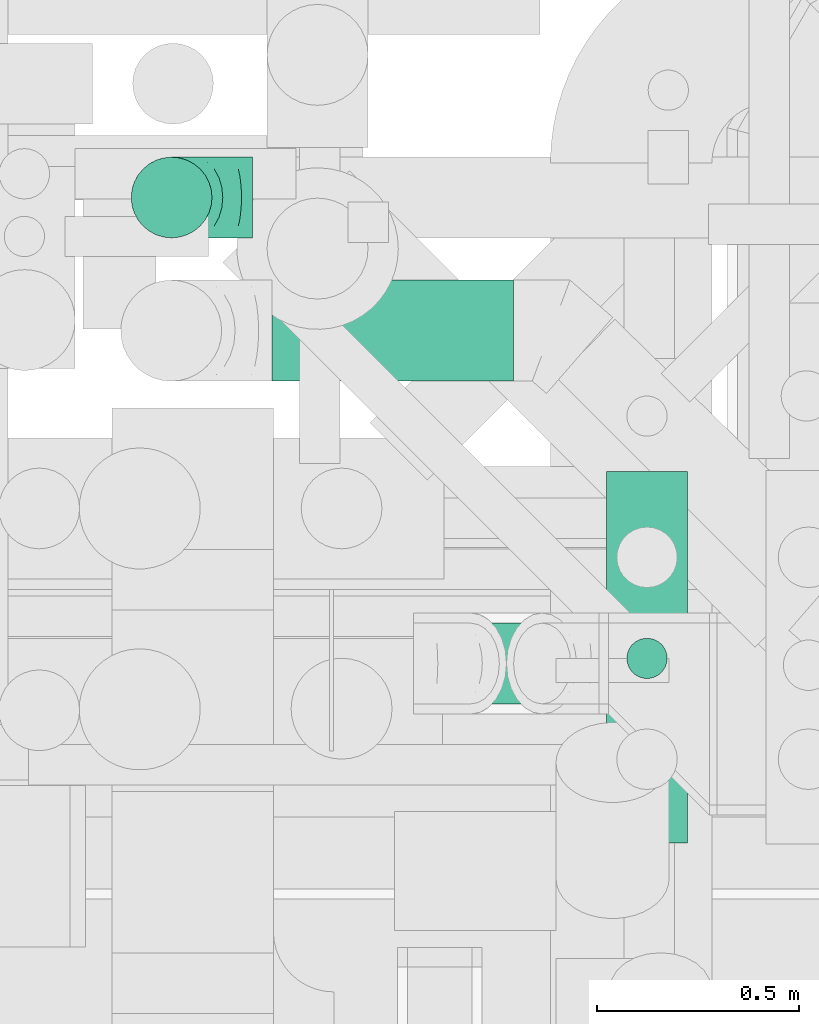
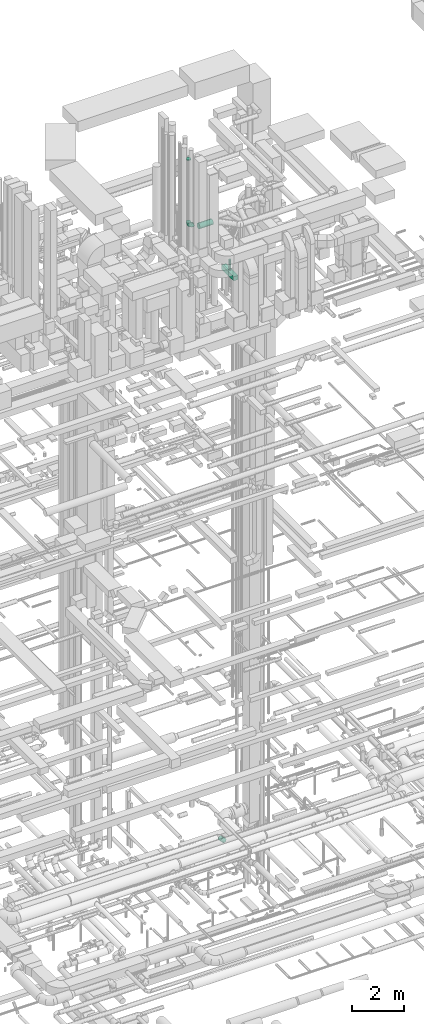
# One storey, part 227 of 337: 4 flow segments, 2 flow fittings.
"""IFC2X3 building model written with IfcOpenShell, lengths in millimetres."""

from ifc_helpers import new_model, entity, si_unit, converted_unit, derived_unit, direction, frame, origin, origin_2d_with_axis, place, context, subcontext, project, spatial, rectangle, circle, extrude, faceted_brep, source, transform, mapped, material, type_object, type_shapes, element, save


model = new_model("IFC2X3")

# Units and contexts
model_context = context("Model", 3, precision=0.01, world=origin(), true_north=direction((6.12303176911189e-17, 1.0)))
body_context = subcontext(model_context, "Body", "Model", "MODEL_VIEW")
ifc_project = project(units=[si_unit("LENGTHUNIT", "METRE", prefix="MILLI"), si_unit("AREAUNIT", "SQUARE_METRE"), si_unit("VOLUMEUNIT", "CUBIC_METRE"), converted_unit("PLANEANGLEUNIT", "DEGREE", entity("IfcRatioMeasure", 0.0174532925199433), si_unit("PLANEANGLEUNIT", "RADIAN"), dimensions=[0, 0, 0, 0, 0, 0, 0]), si_unit("MASSUNIT", "GRAM", prefix="KILO"), derived_unit("MASSDENSITYUNIT", [(si_unit("MASSUNIT", "GRAM", prefix="KILO"), 1), (si_unit("LENGTHUNIT", "METRE"), -3)]), derived_unit("MOMENTOFINERTIAUNIT", [(si_unit("LENGTHUNIT", "METRE"), 4)]), si_unit("TIMEUNIT", "SECOND"), si_unit("FREQUENCYUNIT", "HERTZ"), si_unit("THERMODYNAMICTEMPERATUREUNIT", "DEGREE_CELSIUS"), derived_unit("THERMALTRANSMITTANCEUNIT", [(si_unit("MASSUNIT", "GRAM", prefix="KILO"), 1), (si_unit("THERMODYNAMICTEMPERATUREUNIT", "KELVIN"), -1), (si_unit("TIMEUNIT", "SECOND"), -3)]), derived_unit("VOLUMETRICFLOWRATEUNIT", [(si_unit("LENGTHUNIT", "METRE"), 3), (si_unit("TIMEUNIT", "SECOND"), -1)]), derived_unit("MASSFLOWRATEUNIT", [(si_unit("MASSUNIT", "GRAM", prefix="KILO"), 1), (si_unit("TIMEUNIT", "SECOND"), -1)]), derived_unit("ROTATIONALFREQUENCYUNIT", [(si_unit("TIMEUNIT", "SECOND"), -1)]), si_unit("ELECTRICCURRENTUNIT", "AMPERE"), si_unit("ELECTRICVOLTAGEUNIT", "VOLT"), si_unit("POWERUNIT", "WATT"), si_unit("FORCEUNIT", "NEWTON", prefix="KILO"), si_unit("ILLUMINANCEUNIT", "LUX"), si_unit("LUMINOUSFLUXUNIT", "LUMEN"), si_unit("LUMINOUSINTENSITYUNIT", "CANDELA"), derived_unit("USERDEFINED", [(si_unit("MASSUNIT", "GRAM", prefix="KILO"), -1), (si_unit("LENGTHUNIT", "METRE"), -2), (si_unit("TIMEUNIT", "SECOND"), 3), (si_unit("LUMINOUSFLUXUNIT", "LUMEN"), 1)]), derived_unit("LINEARVELOCITYUNIT", [(si_unit("LENGTHUNIT", "METRE"), 1), (si_unit("TIMEUNIT", "SECOND"), -1)]), si_unit("PRESSUREUNIT", "PASCAL"), derived_unit("USERDEFINED", [(si_unit("LENGTHUNIT", "METRE"), -2), (si_unit("MASSUNIT", "GRAM", prefix="KILO"), 1), (si_unit("TIMEUNIT", "SECOND"), -2)]), derived_unit("LINEARFORCEUNIT", [(si_unit("MASSUNIT", "GRAM", prefix="KILO"), 1), (si_unit("LENGTHUNIT", "METRE"), 1), (si_unit("TIMEUNIT", "SECOND"), -2), (si_unit("LENGTHUNIT", "METRE"), -1)]), derived_unit("PLANARFORCEUNIT", [(si_unit("MASSUNIT", "GRAM", prefix="KILO"), 1), (si_unit("LENGTHUNIT", "METRE"), 1), (si_unit("TIMEUNIT", "SECOND"), -2), (si_unit("LENGTHUNIT", "METRE"), -2)])], contexts=[model_context])

# Site, building, storey
site_placement = place(None, origin())
site = spatial("IfcSite", under=ifc_project, at=site_placement, CompositionType="ELEMENT")
building_placement = place(site_placement, origin())
building = spatial("IfcBuilding", under=site, at=building_placement, CompositionType="ELEMENT")
storey_placement = place(building_placement, origin())
storey = spatial("IfcBuildingStorey", under=building, at=storey_placement, CompositionType="ELEMENT", Elevation=0.0)

# Flow segments
duct_segment_type_1 = type_object("IfcDuctSegmentType", PredefinedType="NOTDEFINED")
flow_segment_1_placement = place(storey_placement, frame((57036.5, 9405.81, 29700.0)))
element("IfcFlowSegment", 1, at=flow_segment_1_placement, inside=storey, type_object=duct_segment_type_1, context=body_context, shape_type="SweptSolid", body=[
    extrude(rectangle(XDim=920.0, YDim=199.999999999998, at=origin_2d_with_axis()), frame((100.0, 460.0, 0.0), z_axis=(0.0, 0.0, 1.0), x_axis=(0.0, 1.0, 0.0)), (0.0, 0.0, 1.0), 199.999999999998),
])
duct_segment_type_2 = type_object("IfcDuctSegmentType", PredefinedType="NOTDEFINED")
flow_segment_2_placement = place(storey_placement, frame((56208.0, 10547.9, 31673.4)))
element("IfcFlowSegment", 2, at=flow_segment_2_placement, inside=storey, type_object=duct_segment_type_2, context=body_context, shape_type="SweptSolid", body=[
    extrude(circle(Radius=125.0, at=origin_2d_with_axis()), frame((0.0, 126.6, 126.6), z_axis=(1.0, 0.0, 0.0), x_axis=(0.0, -1.0, 0.0)), (0.0, 0.0, 1.0), 597.503933564567),
])
flow_segment_3_placement = place(storey_placement, frame((57084.9, 9811.22, 29920.0)))
element("IfcFlowSegment", 3, at=flow_segment_3_placement, inside=storey, type_object=duct_segment_type_2, context=body_context, shape_type="SweptSolid", body=[
    extrude(circle(Radius=50.0, at=origin_2d_with_axis()), frame((51.6, 51.6, 0.0)), (0.0, 0.0, 1.0), 484.999999999994),
])
flow_segment_4_placement = place(storey_placement, frame((56627.81, 9748.4, 3212.47)))
element("IfcFlowSegment", 4, at=flow_segment_4_placement, inside=storey, type_object=duct_segment_type_2, context=body_context, shape_type="SweptSolid", body=[
    extrude(circle(Radius=100.0, at=origin_2d_with_axis()), frame((72.31, 101.6, 248.95), z_axis=(0.707106630945554, 0.0, -0.707106931427509), x_axis=(0.0, 1.0, 0.0)), (0.0, 0.0, 1.0), 249.807984266278),
])

# Flow fittings
ifc_material = material()
duct_fitting_type_1 = type_object("IfcDuctFittingType", PredefinedType="NOTDEFINED", material=ifc_material)
shared_shape_1 = source(origin(), body_context, "Body", "SweptSolid", [
    extrude(circle(Radius=99.9999999999994, at=origin_2d_with_axis()), frame((0.0, 0.0, 0.0), z_axis=(1.0, 0.0, 0.0), x_axis=(0.0, 1.0, 0.0)), (0.0, 0.0, 1.0), 25.0000000000018),
])
type_shapes(duct_fitting_type_1, [shared_shape_1])
flow_fitting_1_placement = place(storey_placement, frame((55959.0, 11004.22, 34820.0), z_axis=(-1.0, 0.0, 0.0), x_axis=(0.0, 0.0, 1.0)))
element("IfcFlowFitting", 5, at=flow_fitting_1_placement, inside=storey, type_object=duct_fitting_type_1, material=ifc_material, context=body_context, shape_type="MappedRepresentation", body=[
    mapped(shared_shape_1, transform((0.0, 0.0, 0.0), scale=1.0)),
])
duct_fitting_type_2 = type_object("IfcDuctFittingType", PredefinedType="NOTDEFINED", material=ifc_material)
shared_shape_2 = source(origin(), body_context, "Body", "Brep", [
    faceted_brep([(-200.0, 0.0, -100.0), (-200.0, -25.88, -96.59), (-200.0, -50.0, -86.6), (-200.0, -70.71, -70.71), (-200.0, -86.6, -50.0), (-200.0, -96.59, -25.88), (-200.0, -100.0, 0.0), (-200.0, -96.59, 25.88), (-200.0, -86.6, 50.0), (-200.0, -70.71, 70.71), (-200.0, -50.0, 86.6), (-200.0, -25.88, 96.59), (-200.0, 0.0, 100.0), (-200.0, 25.88, 96.59), (-200.0, 50.0, 86.6), (-200.0, 70.71, 70.71), (-200.0, 86.6, 50.0), (-200.0, 96.59, 25.88), (-200.0, 100.0, 0.0), (-200.0, 96.59, -25.88), (-200.0, 86.6, -50.0), (-200.0, 70.71, -70.71), (-200.0, 50.0, -86.6), (-200.0, 25.88, -96.59), (-153.35, 25.88, 96.59), (-159.81, 50.0, 86.6), (-146.41, 0.0, 100.0), (-165.36, 70.71, 70.71), (-172.29, 96.59, 25.88), (-173.21, 100.0, 0.0), (-169.62, 86.6, 50.0), (-169.62, 86.6, -50.0), (-165.36, 70.71, -70.71), (-172.29, 96.59, -25.88), (-153.35, 25.88, -96.59), (-146.41, 0.0, -100.0), (-159.81, 50.0, -86.6), (-139.48, -25.88, -96.59), (-133.01, -50.0, -86.6), (-127.46, -70.71, -70.71), (-123.21, -86.6, -50.0), (-120.53, -96.59, -25.88), (-119.62, -100.0, 0.0), (-120.53, -96.59, 25.88), (-123.21, -86.6, 50.0), (-127.46, -70.71, 70.71), (-133.01, -50.0, 86.6), (-139.48, -25.88, 96.59), (-72.54, 72.54, 96.59), (-90.19, 90.19, 86.6), (-53.59, 53.59, 100.0), (-105.35, 105.35, 70.71), (-116.99, 116.99, 50.0), (-124.3, 124.3, 25.88), (-126.79, 126.79, 0.0), (-124.3, 124.3, -25.88), (-116.99, 116.99, -50.0), (-105.35, 105.35, -70.71), (-72.54, 72.54, -96.59), (-53.59, 53.59, -100.0), (-90.19, 90.19, -86.6), (-34.64, 34.64, -96.59), (-16.99, 16.99, -86.6), (-1.83, 1.83, -70.71), (9.81, -9.81, -50.0), (17.12, -17.12, -25.88), (19.62, -19.62, 0.0), (17.12, -17.12, 25.88), (9.81, -9.81, 50.0), (-1.83, 1.83, 70.71), (-16.99, 16.99, 86.6), (-34.64, 34.64, 96.59), (-25.88, 153.35, 96.59), (-50.0, 159.81, 86.6), (0.0, 146.41, 100.0), (-70.71, 165.36, 70.71), (-86.6, 169.62, 50.0), (-96.59, 172.29, 25.88), (-100.0, 173.21, 0.0), (-96.59, 172.29, -25.88), (-86.6, 169.62, -50.0), (-70.71, 165.36, -70.71), (-25.88, 153.35, -96.59), (0.0, 146.41, -100.0), (-50.0, 159.81, -86.6), (25.88, 139.48, -96.59), (50.0, 133.01, -86.6), (70.71, 127.46, -70.71), (86.6, 123.21, -50.0), (96.59, 120.53, -25.88), (100.0, 119.62, 0.0), (96.59, 120.53, 25.88), (86.6, 123.21, 50.0), (70.71, 127.46, 70.71), (50.0, 133.01, 86.6), (25.88, 139.48, 96.59), (-25.88, 200.0, -96.59), (-50.0, 200.0, -86.6), (-70.71, 200.0, -70.71), (-86.6, 200.0, -50.0), (-96.59, 200.0, -25.88), (-100.0, 200.0, 0.0), (-96.59, 200.0, 25.88), (-86.6, 200.0, 50.0), (-70.71, 200.0, 70.71), (-50.0, 200.0, 86.6), (-25.88, 200.0, 96.59), (0.0, 200.0, 100.0), (25.88, 200.0, 96.59), (50.0, 200.0, 86.6), (70.71, 200.0, 70.71), (86.6, 200.0, 50.0), (96.59, 200.0, 25.88), (100.0, 200.0, 0.0), (96.59, 200.0, -25.88), (86.6, 200.0, -50.0), (70.71, 200.0, -70.71), (50.0, 200.0, -86.6), (25.88, 200.0, -96.59), (0.0, 200.0, -100.0)], [[[0, 1, 2, 3, 4, 5, 6, 7, 8, 9, 10, 11, 12, 13, 14, 15, 16, 17, 18, 19, 20, 21, 22, 23]], [[24, 25, 14, 13]], [[26, 24, 13, 12]], [[14, 25, 27, 15]], [[28, 29, 18, 17]], [[30, 28, 17, 16]], [[15, 27, 30, 16]], [[20, 31, 32, 21]], [[33, 31, 20, 19]], [[18, 29, 33, 19]], [[34, 35, 0, 23]], [[36, 34, 23, 22]], [[32, 36, 22, 21]], [[1, 0, 35, 37]], [[2, 1, 37, 38]], [[38, 39, 3, 2]], [[5, 4, 40, 41]], [[6, 5, 41, 42]], [[39, 40, 4, 3]], [[6, 42, 43, 7]], [[7, 43, 44, 8]], [[8, 44, 45, 9]], [[9, 45, 46, 10]], [[10, 46, 47, 11]], [[26, 12, 11, 47]], [[48, 49, 25, 24]], [[50, 48, 24, 26]], [[27, 25, 49, 51]], [[52, 53, 28, 30]], [[51, 52, 30, 27]], [[29, 28, 53, 54]], [[55, 56, 31, 33]], [[54, 55, 33, 29]], [[32, 31, 56, 57]], [[58, 59, 35, 34]], [[60, 58, 34, 36]], [[57, 60, 36, 32]], [[37, 35, 59, 61]], [[38, 37, 61, 62]], [[39, 38, 62, 63]], [[41, 40, 64, 65]], [[42, 41, 65, 66]], [[63, 64, 40, 39]], [[43, 42, 66, 67]], [[44, 43, 67, 68]], [[68, 69, 45, 44]], [[46, 45, 69, 70]], [[47, 46, 70, 71]], [[26, 47, 71, 50]], [[72, 73, 49, 48]], [[74, 72, 48, 50]], [[51, 49, 73, 75]], [[76, 77, 53, 52]], [[75, 76, 52, 51]], [[54, 53, 77, 78]], [[79, 80, 56, 55]], [[78, 79, 55, 54]], [[57, 56, 80, 81]], [[82, 83, 59, 58]], [[84, 82, 58, 60]], [[81, 84, 60, 57]], [[61, 59, 83, 85]], [[62, 61, 85, 86]], [[63, 62, 86, 87]], [[65, 64, 88, 89]], [[66, 65, 89, 90]], [[87, 88, 64, 63]], [[67, 66, 90, 91]], [[68, 67, 91, 92]], [[92, 93, 69, 68]], [[70, 69, 93, 94]], [[71, 70, 94, 95]], [[50, 71, 95, 74]], [[96, 97, 98, 99, 100, 101, 102, 103, 104, 105, 106, 107, 108, 109, 110, 111, 112, 113, 114, 115, 116, 117, 118, 119]], [[72, 74, 107, 106]], [[73, 72, 106, 105]], [[75, 73, 105, 104]], [[102, 101, 78, 77]], [[103, 102, 77, 76]], [[75, 104, 103, 76]], [[78, 101, 100, 79]], [[79, 100, 99, 80]], [[80, 99, 98, 81]], [[84, 97, 96, 82]], [[82, 96, 119, 83]], [[84, 81, 98, 97]], [[118, 117, 86, 85]], [[119, 118, 85, 83]], [[116, 87, 86, 117]], [[88, 115, 114, 89]], [[89, 114, 113, 90]], [[115, 88, 87, 116]], [[91, 90, 113, 112]], [[92, 91, 112, 111]], [[111, 110, 93, 92]], [[95, 94, 109, 108]], [[74, 95, 108, 107]], [[110, 109, 94, 93]]]),
])
type_shapes(duct_fitting_type_2, [shared_shape_2])
flow_fitting_2_placement = place(storey_placement, frame((55959.0, 11004.22, 31701.04), z_axis=(0.0, 1.0, 0.0), x_axis=(-1.0, 0.0, 0.0)))
element("IfcFlowFitting", 6, at=flow_fitting_2_placement, inside=storey, type_object=duct_fitting_type_2, material=ifc_material, context=body_context, shape_type="MappedRepresentation", body=[
    mapped(shared_shape_2, transform((0.0, 0.0, 0.0), scale=1.0)),
])

save(model, "model.ifc")
